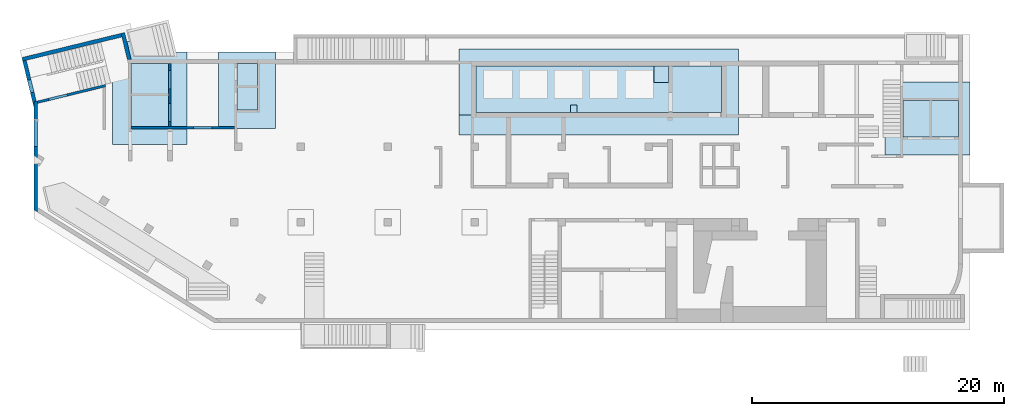
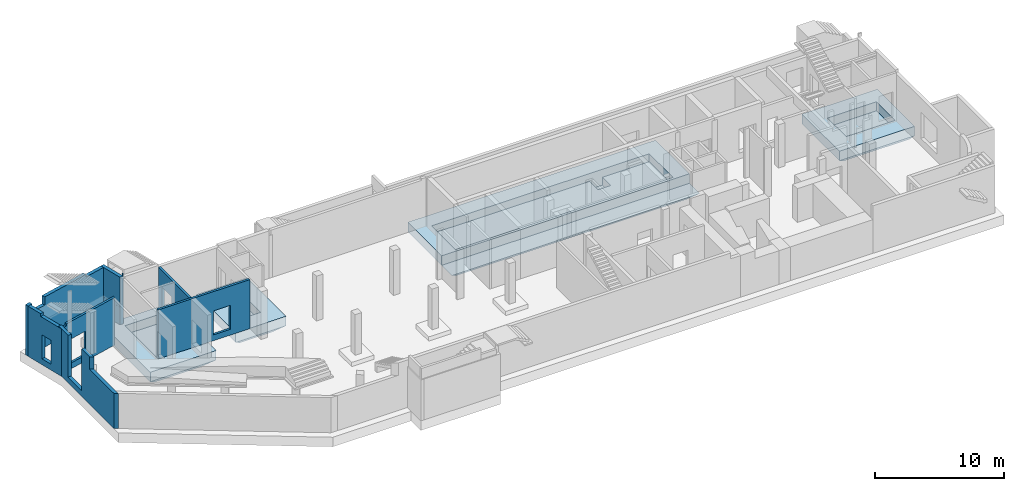
# One storey, part 5 of 9: 7 walls, 4 slabs, 7 openings.
"""IFC4 building model written with IfcOpenShell, lengths in millimetres."""

from ifc_helpers import new_model, entity, si_unit, converted_unit, derived_unit, direction, frame, origin, place, context, subcontext, project, spatial, indexed_curve, outline, extrude, polygons, material, type_object, element, save


model = new_model("IFC4")

# Units and contexts
model_context = context("Model", 3, precision=0.01, world=origin(), true_north=direction((6.12303176911189e-17, 1.0)))
plan_context = context("Plan", 3, precision=0.01, world=origin(), true_north=direction((6.12303176911189e-17, 1.0)))
body_context = subcontext(model_context, "Body", "Model", "MODEL_VIEW")
ifc_project = project(units=[si_unit("LENGTHUNIT", "METRE", prefix="MILLI"), si_unit("AREAUNIT", "SQUARE_METRE"), si_unit("VOLUMEUNIT", "CUBIC_METRE"), converted_unit("PLANEANGLEUNIT", "DEGREE", entity("IfcRatioMeasure", 0.0174532925199433), si_unit("PLANEANGLEUNIT", "RADIAN"), dimensions=[0, 0, 0, 0, 0, 0, 0]), si_unit("MASSUNIT", "GRAM", prefix="KILO"), derived_unit("MASSDENSITYUNIT", [(si_unit("MASSUNIT", "GRAM", prefix="KILO"), 1), (si_unit("LENGTHUNIT", "METRE"), -3)]), derived_unit("MOMENTOFINERTIAUNIT", [(si_unit("LENGTHUNIT", "METRE"), 4)]), si_unit("TIMEUNIT", "SECOND"), si_unit("FREQUENCYUNIT", "HERTZ"), si_unit("THERMODYNAMICTEMPERATUREUNIT", "DEGREE_CELSIUS"), derived_unit("THERMALTRANSMITTANCEUNIT", [(si_unit("MASSUNIT", "GRAM", prefix="KILO"), 1), (si_unit("THERMODYNAMICTEMPERATUREUNIT", "KELVIN"), -1), (si_unit("TIMEUNIT", "SECOND"), -3)]), derived_unit("VOLUMETRICFLOWRATEUNIT", [(si_unit("LENGTHUNIT", "METRE"), 3), (si_unit("TIMEUNIT", "SECOND"), -1)]), derived_unit("MASSFLOWRATEUNIT", [(si_unit("MASSUNIT", "GRAM", prefix="KILO"), 1), (si_unit("TIMEUNIT", "SECOND"), -1)]), derived_unit("ROTATIONALFREQUENCYUNIT", [(si_unit("TIMEUNIT", "SECOND"), -1)]), si_unit("ELECTRICCURRENTUNIT", "AMPERE"), si_unit("ELECTRICVOLTAGEUNIT", "VOLT"), si_unit("POWERUNIT", "WATT"), si_unit("FORCEUNIT", "NEWTON", prefix="KILO"), si_unit("ILLUMINANCEUNIT", "LUX"), si_unit("LUMINOUSFLUXUNIT", "LUMEN"), si_unit("LUMINOUSINTENSITYUNIT", "CANDELA"), derived_unit("USERDEFINED", [(si_unit("MASSUNIT", "GRAM", prefix="KILO"), -1), (si_unit("LENGTHUNIT", "METRE"), -2), (si_unit("TIMEUNIT", "SECOND"), 3), (si_unit("LUMINOUSFLUXUNIT", "LUMEN"), 1)]), derived_unit("LINEARVELOCITYUNIT", [(si_unit("LENGTHUNIT", "METRE"), 1), (si_unit("TIMEUNIT", "SECOND"), -1)]), si_unit("PRESSUREUNIT", "PASCAL"), derived_unit("USERDEFINED", [(si_unit("LENGTHUNIT", "METRE"), -2), (si_unit("MASSUNIT", "GRAM", prefix="KILO"), 1), (si_unit("TIMEUNIT", "SECOND"), -2)]), derived_unit("LINEARFORCEUNIT", [(si_unit("MASSUNIT", "GRAM", prefix="KILO"), 1), (si_unit("LENGTHUNIT", "METRE"), 1), (si_unit("TIMEUNIT", "SECOND"), -2), (si_unit("LENGTHUNIT", "METRE"), -1)]), derived_unit("PLANARFORCEUNIT", [(si_unit("MASSUNIT", "GRAM", prefix="KILO"), 1), (si_unit("LENGTHUNIT", "METRE"), 1), (si_unit("TIMEUNIT", "SECOND"), -2), (si_unit("LENGTHUNIT", "METRE"), -2)])], contexts=[model_context, plan_context])

# Site, building, storey
site_placement = place(None, origin())
site = spatial("IfcSite", under=ifc_project, at=site_placement, CompositionType="ELEMENT")
building_placement = place(site_placement, origin())
building = spatial("IfcBuilding", under=site, at=building_placement, CompositionType="ELEMENT")
storey_placement = place(building_placement, frame((0.0, 0.0, -4900.0)))
storey = spatial("IfcBuildingStorey", under=building, at=storey_placement, CompositionType="ELEMENT", Elevation=-4900.0)

# Slabs
ifc_material = material()
slab_type_1 = type_object("IfcSlabType", PredefinedType="BASESLAB", material=ifc_material)
slab_1_placement = place(storey_placement, frame((67520.0002685546, 13019.999226356, -1750.0)))
element("IfcSlab", 1, at=slab_1_placement, inside=storey, type_object=slab_type_1, PredefinedType="BASESLAB", context=body_context, shape_type="Tessellation", body=[
    polygons([(1450.00000000004, 4349.99999999999, 1750.0), (5850.00000000005, 4349.99999999999, 1750.0), (5850.00000000005, 1449.99999999998, 1750.0), (1450.00000000004, 1449.99999999998, 1750.0), (6750.00000000002, 5799.99999999999, 1750.0), (4.33146851719357e-11, 5799.99999999999, 1750.0), (4.33146851719357e-11, -2.16573425859679e-12, 1750.0), (6750.00000000002, -2.16573425859679e-12, 1750.0), (6750.00000000002, 4949.99999999999, 0.0), (6750.00000000002, 850.000000000025, 0.0), (850.000000000006, 850.000000000025, 0.0), (850.000000000023, 4949.99999999999, 0.0), (6750.00000000002, 5799.99999999999, 849.999999999998), (4.33146851719357e-11, 5799.99999999999, 849.999999999997), (3.46517481375486e-11, 1.51601398101775e-11, 849.999999999995), (6750.00000000002, -2.16573425859679e-12, 850.00000000002), (5850.00000000005, 4349.99999999999, 899.999999999999), (3750.00000000004, 4349.99999999999, 899.999999999999), (3550.00000000004, 4349.99999999999, 899.999999999999), (1450.00000000004, 4349.99999999999, 899.999999999999), (1450.00000000004, 1449.99999999998, 899.999999999999), (3550.00000000003, 1449.99999999998, 899.999999999999), (3750.00000000003, 1449.99999999998, 899.999999999999), (5850.00000000005, 1449.99999999998, 899.999999999999)], [[[5, 6, 7, 8], [1, 2, 3, 4]], [[9, 10, 11, 12]], [[6, 5, 13, 14]], [[7, 6, 14, 15]], [[8, 7, 15, 16]], [[5, 8, 16, 10, 9, 13]], [[11, 10, 16, 15]], [[9, 12, 14, 13]], [[12, 11, 15, 14]], [[17, 18, 19, 20, 21, 22, 23, 24]], [[2, 1, 20, 19, 18, 17]], [[1, 4, 21, 20]], [[4, 3, 24, 23, 22, 21]], [[3, 2, 17, 24]]], closed=True),
])
slab_type_2 = type_object("IfcSlabType", PredefinedType="BASESLAB", material=ifc_material)
slab_2_placement = place(storey_placement, frame((14650.0002685547, 15149.9992263559, -1750.0)))
element("IfcSlab", 2, at=slab_2_placement, inside=storey, type_object=slab_type_2, PredefinedType="BASESLAB", context=body_context, shape_type="Tessellation", body=[
    polygons([(-2.16573425859679e-12, 6050.00000000001, 1750.00000000001), (1.08286712929839e-11, 0.0, 1750.00000000001), (4525.0, 8.66293703438714e-12, 1750.00000000001), (4524.99999999999, 6050.00000000001, 1750.00000000001), (1450.00000000001, 1450.0, 1750.0), (1450.0, 5150.0, 1750.0), (3075.0, 5150.00000000001, 1750.0), (3075.0, 5100.00000000023, 1750.00000000001), (3075.00000000001, 1450.00000000001, 1750.0), (849.999999999993, 6050.00000000001, 4.33146851719357e-12), (3674.99999999997, 6050.00000000001, 3.24860138789518e-12), (3674.99999999998, 849.99999999998, 5.41433564649196e-12), (850.000000000002, 849.999999999995, 3.24860138789518e-12), (-2.16573425859679e-12, 6050.00000000001, 850.0), (1.08286712929839e-11, 0.0, 850.000000000001), (4524.99999999998, 6.49720277579036e-12, 850.000000000001), (4524.99999999999, 6050.00000000001, 850.00000000002), (1450.0, 5150.0, 900.000000000003), (1450.00000000001, 1450.0, 900.000000000003), (3075.00000000001, 1450.00000000001, 900.000000000003), (3075.0, 5150.00000000001, 900.000000000003)], [[[1, 2, 3, 4], [5, 6, 7, 8, 9]], [[10, 11, 12, 13]], [[2, 1, 14, 15]], [[3, 2, 15, 16]], [[4, 3, 16, 17]], [[1, 4, 17, 11, 10, 14]], [[12, 11, 17, 16]], [[10, 13, 15, 14]], [[13, 12, 16, 15]], [[18, 19, 20, 21]], [[6, 5, 19, 18]], [[5, 9, 20, 19]], [[9, 8, 7, 21, 20]], [[7, 6, 18, 21]]], closed=True),
])
slab_type_3 = type_object("IfcSlabType", PredefinedType="BASESLAB", material=ifc_material)
slab_3_placement = place(storey_placement, frame((6250.00026855467, 13849.9992263559, -1750.0)))
element("IfcSlab", 3, at=slab_3_placement, inside=storey, type_object=slab_type_3, PredefinedType="BASESLAB", context=body_context, shape_type="Tessellation", body=[
    polygons([(-1.08286712929839e-12, 8200.00000000004, 1750.00000000001), (1.40772726808791e-11, 3.68174823961454e-11, 1750.00000000001), (5900.00000000001, 4.54804194305325e-11, 1750.00000000001), (5900.0, 7350.00000000009, 1750.00000000001), (1950.50878437107, 7350.0000000001, 1750.0), (1743.31229154819, 8200.00000000004, 1750.00000000001), (1450.00000000001, 1450.00000000004, 1750.0), (1450.0, 6450.00000000009, 1750.0), (4450.0, 6450.0000000001, 1750.0), (4450.00000000001, 1450.00000000005, 1750.0), (5049.99999999999, 849.999999999991, 3.24860138789518e-12), (850.000000000003, 850.000000000015, 4.33146851719357e-12), (849.999999999993, 7350.00000000009, 3.24860138789518e-12), (1950.50878437107, 7350.0000000001, 4.33146851719357e-12), (5049.99999999998, 7350.00000000009, 5.41433564649196e-12), (3.24860138789518e-12, 8200.00000000005, 849.999999999984), (1.40772726808791e-11, 3.46517481375486e-11, 849.999999999995), (5900.00000000001, 3.46517481375486e-11, 849.999999999996), (5900.0, 7350.00000000009, 850.00000000002), (1743.31229154819, 8200.00000000004, 849.999999999957), (1450.0, 6450.00000000009, 900.000000000003), (1450.00000000001, 1450.00000000004, 900.000000000003), (4450.00000000001, 1450.00000000005, 900.000000000003), (4450.0, 6450.0000000001, 900.000000000003)], [[[1, 2, 3, 4, 5, 6], [7, 8, 9, 10]], [[11, 12, 13, 14, 15]], [[2, 1, 16, 17]], [[3, 2, 17, 18]], [[3, 18, 19, 4]], [[16, 1, 6, 20]], [[18, 11, 15, 19]], [[17, 16, 13, 12]], [[12, 11, 18, 17]], [[21, 22, 23, 24]], [[8, 7, 22, 21]], [[7, 10, 23, 22]], [[10, 9, 24, 23]], [[9, 8, 21, 24]], [[13, 16, 20, 14]], [[5, 4, 19, 15, 14]], [[6, 5, 14, 20]]], closed=True),
])
slab_type_4 = type_object("IfcSlabType", PredefinedType="BASESLAB", material=ifc_material)
slab_4_placement = place(storey_placement, frame((33720.0002685547, 14599.9992263559, -1800.0)))
element("IfcSlab", 4, at=slab_4_placement, inside=storey, type_object=slab_type_4, PredefinedType="BASESLAB", context=body_context, shape_type="Tessellation", body=[
    polygons([(22200.0, 6850.00000000012, 1800.0), (-4.33146851719357e-12, 6850.00000000008, 1800.0), (8.66293703438714e-12, 1600.00000000008, 1800.0), (22200.0, 1600.00000000012, 1800.0), (20850.0, 5500.00000000027, 1800.00000000001), (20850.0, 1800.00000000025, 1800.00000000001), (1350.00000000001, 1800.00000000021, 1800.00000000001), (1350.00000000001, 5500.00000000024, 1800.00000000001), (21450.0, 750.000000000005, 150.000000000005), (750.00000000002, 750.000000000109, 150.000000000004), (750.000000000016, 3850.00000000021, 150.000000000005), (750.000000000011, 6100.00000000015, 150.000000000005), (15150.0, 6100.00000000015, 150.000000000005), (15150.0, 5500.00000000026, 150.000000000005), (15150.0, 3850.00000000016, 150.000000000002), (17000.0, 3850.00000000016, 150.000000000008), (17000.0, 5500.00000000026, 150.000000000005), (17000.0, 6100.00000000015, 150.000000000006), (21450.0, 6100.00000000015, 150.000000000005), (21450.0, 3850.00000000015, 150.000000000005), (4.33146851719357e-12, 6850.00000000009, 899.999999999995), (1.29944055515807e-11, 1600.00000000008, 900.000000000014), (22200.0, 6850.00000000012, 899.99999999999), (22200.0, 1600.00000000012, 900.000000000003), (1350.00000000001, 5500.00000000024, 1050.00000000001), (15500.0, 5500.00000000023, 1050.00000000001), (15500.0, 5500.00000000017, 300.000000000005), (16650.0, 5500.0000000002, 300.000000000005), (16650.0, 5500.00000000027, 1050.00000000001), (16950.0, 5500.00000000027, 1050.00000000001), (20850.0, 5500.00000000027, 1050.00000000001), (15300.0, 5950.00000000015, 3.24860138789518e-12), (16850.0, 5950.00000000015, 5.41433564649196e-12), (16850.0, 4000.00000000016, 7.58006990508875e-12), (15300.0, 4000.00000000016, 7.58006990508875e-12), (22200.0, 5.84748249821132e-11, 899.999999999991), (1.29944055515807e-11, 9.52923073782586e-11, 900.000000000013), (1350.00000000001, 1800.00000000021, 1050.00000000001), (8860.00000000002, 1800.00000000022, 1050.00000000001), (8860.00000000002, 2400.00000000022, 1050.00000000001), (9360.00000000002, 2400.00000000022, 1050.00000000001), (9360.00000000002, 1800.00000000022, 1050.00000000001), (16650.0, 1800.00000000024, 1050.00000000001), (16950.0, 1800.00000000024, 1050.00000000001), (20850.0, 1800.00000000025, 1050.00000000001), (16650.0, 4200.00000000016, 1050.00000000001), (15500.0, 4200.00000000016, 1050.00000000001), (9360.00000000002, 1800.00000000022, 800.000000000005), (8860.00000000002, 1800.00000000022, 800.000000000005), (9360.00000000002, 2400.00000000022, 800.000000000005), (8860.00000000002, 2400.00000000022, 800.000000000005), (15500.0, 4200.00000000016, 300.000000000005), (16650.0, 4200.00000000016, 300.000000000005)], [[[1, 2, 3, 4], [5, 6, 7, 8]], [[9, 10, 11, 12, 13, 14, 15, 16, 17, 18, 19, 20]], [[2, 21, 22, 3]], [[23, 1, 4, 24]], [[2, 1, 23, 21]], [[8, 25, 26, 27, 28, 29, 30, 31, 5]], [[32, 33, 34, 35]], [[20, 19, 23, 24, 36, 9]], [[11, 10, 37, 22, 21, 12]], [[10, 9, 36, 37]], [[25, 38, 39, 40, 41, 42, 43, 44, 45, 31, 30, 29, 46, 47, 26]], [[8, 7, 38, 25]], [[7, 6, 45, 44, 43, 42, 48, 49, 39, 38]], [[6, 5, 31, 45]], [[33, 32, 13, 12, 21, 23, 19, 18]], [[49, 48, 50, 51]], [[42, 41, 50, 48]], [[41, 40, 51, 50]], [[40, 39, 49, 51]], [[35, 34, 16, 15]], [[34, 33, 18, 17, 16]], [[32, 35, 15, 14, 13]], [[28, 27, 52, 53]], [[26, 47, 52, 27]], [[47, 46, 53, 52]], [[46, 29, 28, 53]], [[24, 22, 37, 36]], [[22, 24, 4, 3]]], closed=True),
])

# Wall, openings
wall_type_1 = type_object("IfcWallType", PredefinedType="STANDARD")
wall_1_placement = place(storey_placement, frame((10800.0002685547, 20299.9992263564, 0.0), z_axis=(0.0, 0.0, 1.0), x_axis=(0.0, -1.0, 0.0)))
wall_1 = element("IfcWall", 5, at=wall_1_placement, inside=storey, type_object=wall_type_1, material=ifc_material, PredefinedType="NOTDEFINED", context=body_context, shape_type="Tessellation", body=[
    polygons([(579.999999999998, -100.000000000002, 2919.99999999804), (2020.0, -100.000000000002, 2919.99999999804), (2020.0, -100.000000000002, 550.0), (579.999999999998, -100.000000000002, 550.0), (3180.0, -100.000000000002, 2919.99999999804), (4620.0, -100.000000000002, 2919.99999999804), (4620.0, -100.000000000002, 550.0), (3180.0, -100.000000000002, 550.0), (0.0, -100.000000000002, 0.0), (2399.99999999999, -100.000000000001, 0.0), (2599.99999999999, -100.000000000001, 0.0), (5000.00000000048, -100.000000000002, 0.0), (5000.00000000048, -100.000000000002, 4500.0), (0.0, -100.000000000002, 4500.0), (5000.00000000048, 99.9999999999976, 0.0), (0.0, 99.9999999999985, 0.0), (0.0, 99.9999999999985, 4500.0), (5000.00000000048, 99.9999999999976, 4500.0), (2020.0, 99.9999999999977, 2919.99999999804), (579.999999999998, 99.9999999999976, 2919.99999999804), (579.999999999998, 99.9999999999976, 550.0), (2020.0, 99.9999999999977, 550.0), (4620.0, 99.9999999999982, 2919.99999999804), (3180.0, 99.9999999999981, 2919.99999999804), (3180.0, 99.9999999999981, 550.0), (4620.0, 99.9999999999982, 550.0)], [[[9, 10, 11, 12, 13, 14], [1, 2, 3, 4], [5, 6, 7, 8]], [[15, 16, 17, 18], [19, 20, 21, 22], [23, 24, 25, 26]], [[12, 11, 10, 9, 16, 15]], [[14, 13, 18, 17]], [[9, 14, 17, 16]], [[13, 12, 15, 18]], [[19, 2, 1, 20]], [[20, 1, 4, 21]], [[21, 4, 3, 22]], [[2, 19, 22, 3]], [[23, 6, 5, 24]], [[24, 5, 8, 25]], [[25, 8, 7, 26]], [[6, 23, 26, 7]]], closed=True),
])
opening_1_placement = place(wall_1_placement, frame((20299.9992263564, -10800.0002685547, 0.0), z_axis=(0.0, 0.0, 1.0), x_axis=(0.0, 1.0, 0.0)))
element("IfcOpeningElement", 6, at=opening_1_placement, cuts=wall_1, PredefinedType="OPENING", context=body_context, shape_type="SweptSolid", body=[
    extrude(outline(indexed_curve([(-1184.99999999902, -719.999999999999), (1184.99999999902, -719.999999999999), (1184.99999999902, 720.000000000001), (-1184.99999999902, 720.000000000001), (-1184.99999999902, -719.999999999999)], self_intersect=False)), frame((10600.0002685547, 18999.9992263564, 1735.0), z_axis=(1.0, 0.0, 0.0), x_axis=(0.0, 0.0, -1.0)), (0.0, 0.0, 1.0), 400.000000001943),
])
opening_2_placement = place(wall_1_placement, frame((20299.9992263564, -10800.0002685547, 0.0), z_axis=(0.0, 0.0, 1.0), x_axis=(0.0, 1.0, 0.0)))
element("IfcOpeningElement", 7, at=opening_2_placement, cuts=wall_1, PredefinedType="OPENING", context=body_context, shape_type="SweptSolid", body=[
    extrude(outline(indexed_curve([(-1184.99999999902, -719.999999999999), (1184.99999999902, -719.999999999999), (1184.99999999902, 720.000000000001), (-1184.99999999902, 720.000000000001), (-1184.99999999902, -719.999999999999)], self_intersect=False)), frame((10600.0002685547, 16399.9992263564, 1735.0), z_axis=(1.0, 0.0, 0.0), x_axis=(0.0, 0.0, -1.0)), (0.0, 0.0, 1.0), 400.000000001943),
])

# Wall, opening
wall_2_placement = place(storey_placement, frame((7700.00026855468, 15199.9992263559, 0.0)))
wall_2 = element("IfcWall", 8, at=wall_2_placement, inside=storey, type_object=wall_type_1, material=ifc_material, PredefinedType="NOTDEFINED", context=body_context, shape_type="Tessellation", body=[
    polygons([(1.8769719247939e-12, -100.000000000001, 0.0), (99.9999999999986, -100.000000000001, 0.0), (2900.0, -100.000000000001, 0.0), (3300.0, -99.9999999999989, 0.0), (8199.99999999999, -99.9999999999989, 0.0), (8199.99999999999, -99.9999999999989, 4650.0), (3300.0, -99.9999999999989, 4650.0), (2900.0, -100.000000000001, 4650.0), (99.9999999999986, -100.000000000001, 4650.0), (1.8769719247939e-12, -100.000000000001, 4650.0), (1.8769719247939e-12, -100.000000000001, 4500.0), (4950.0, -100.000000000003, 2829.99999999804), (6450.0, -100.000000000001, 2829.99999999805), (6450.0, -100.000000000001, 550.0), (4950.0, -100.000000000003, 550.0), (8199.99999999999, 99.9999999999989, 0.0), (3200.0, 100.000000000001, 0.0), (3000.0, 99.9999999999989, 0.0), (2.16575659869695e-13, 100.000000000001, 0.0), (2.16575659869695e-13, 100.000000000001, 4650.0), (8199.99999999999, 99.9999999999989, 4650.0), (6450.0, 99.9999999999989, 2829.99999999805), (4950.0, 99.9999999999989, 2829.99999999804), (4950.0, 99.9999999999989, 550.0), (6450.0, 99.9999999999989, 550.0)], [[[1, 2, 3, 4, 5, 6, 7, 8, 9, 10, 11], [12, 13, 14, 15]], [[16, 17, 18, 19, 20, 21], [22, 23, 24, 25]], [[5, 4, 3, 2, 1, 19, 18, 17, 16]], [[10, 9, 8, 7, 6, 21, 20]], [[1, 11, 10, 20, 19]], [[6, 5, 16, 21]], [[22, 13, 12, 23]], [[23, 12, 15, 24]], [[24, 15, 14, 25]], [[13, 22, 25, 14]]], closed=True),
])
opening_3_placement = place(wall_2_placement, frame((-7700.00026855468, -15199.9992263559, 0.0)))
element("IfcOpeningElement", 9, at=opening_3_placement, cuts=wall_2, PredefinedType="OPENING", context=body_context, shape_type="SweptSolid", body=[
    extrude(outline(indexed_curve([(-1139.99999999902, -749.999999999998), (1139.99999999902, -749.999999999998), (1139.99999999902, 750.000000000001), (-1139.99999999902, 750.000000000001), (-1139.99999999902, -749.999999999998)], self_intersect=False)), frame((13400.0002685547, 14999.9992263559, 1690.0), z_axis=(0.0, 1.0, 0.0), x_axis=(0.0, 0.0, -1.0)), (0.0, 0.0, 1.0), 400.000000001943),
])

# Wall
wall_3_placement = place(storey_placement, frame((276.317659255633, 17216.0487599068, 0.0), z_axis=(0.0, 0.0, 1.0), x_axis=(0.971552058141472, 0.236826092990341, 0.0)))
element("IfcWall", 10, at=wall_3_placement, inside=storey, type_object=wall_type_1, material=ifc_material, PredefinedType="NOTDEFINED", context=body_context, shape_type="Tessellation", body=[
    polygons([(-5.41433564649196e-13, -100.000000000001, 0.0), (5352.26080416868, -100.000000000001, 0.0), (5558.1169889444, -100.000000000003, 0.0), (5558.1169889444, -100.000000000001, 4500.0), (5352.26080416868, -100.000000000001, 4500.0), (400.27581160053, -99.9999999999968, 4500.0), (400.27581160053, -100.000000000319, 4300.00000000001), (0.275811600527082, -100.000000000319, 4300.00000000001), (0.275811600527082, -100.000000000001, 4500.0), (0.0, -100.000000000001, 4500.0), (942.275811600532, -100.000000000003, 2829.99999999804), (2442.27581160053, -100.000000000003, 2829.99999999805), (2442.27581160053, -100.000000000003, 550.0), (942.275811600532, -100.000000000003, 550.0), (5606.86910490273, 99.9999999999968, 0.0), (48.7521159583319, 99.9999999999989, 0.0), (48.7521159583308, 99.9999999999989, 4300.00000000001), (400.275811600528, 99.9999999999989, 4300.00000000001), (400.275811600528, 99.9999999999989, 4500.0), (5606.86910490273, 99.9999999999989, 4500.0), (2442.27581160054, 100.000000000001, 2829.99999999805), (942.275811600533, 99.9999999999968, 2829.99999999804), (942.275811600534, 100.000000000001, 550.0), (2442.27581160054, 100.000000000001, 550.0), (0.275811600528165, -98.8685143399134, 4500.0), (0.275811600528165, -98.8685143399134, 4300.00000000001)], [[[1, 2, 3, 4, 5, 6, 7, 8, 9, 10], [11, 12, 13, 14]], [[15, 16, 17, 18, 19, 20], [21, 22, 23, 24]], [[3, 2, 1, 16, 15]], [[4, 3, 15, 20]], [[16, 1, 10, 25, 26, 17]], [[10, 9, 25]], [[21, 12, 11, 22]], [[22, 11, 14, 23]], [[23, 14, 13, 24]], [[12, 21, 24, 13]], [[18, 7, 6, 19]], [[7, 18, 17, 26, 8]], [[8, 26, 25, 9]], [[4, 20, 19, 6, 5]]], closed=True),
])

# Wall, opening
wall_type_2 = type_object("IfcWallType", PredefinedType="STANDARD")
wall_4_placement = place(storey_placement, frame((7058.33717491699, 22718.7484245087, 0.0), z_axis=(0.0, 0.0, 1.0), x_axis=(0.236826092990336, -0.971552058141474, 0.0)))
wall_4 = element("IfcWall", 11, at=wall_4_placement, inside=storey, type_object=wall_type_2, material=ifc_material, PredefinedType="NOTDEFINED", context=body_context, shape_type="Tessellation", body=[
    polygons([(4.33146851719357e-12, -149.999999999999, 0.0), (300.000000000005, -149.999999999999, 0.0), (2144.22404517247, -149.999999999999, 0.0), (2144.22404517247, -149.999999999999, 1670.0), (300.000000000005, -149.999999999998, 1670.0), (300.000000000005, -149.999999999998, 1870.0), (2144.22404517247, -149.999999999999, 1870.0), (2144.22404517246, -149.999999999999, 4500.0), (300.000000000005, -149.999999999999, 4500.0), (4.33146851719357e-12, -149.999999999999, 4500.0), (2217.35221910996, 150.000000000001, 0.0), (4.33146851719357e-12, 150.000000000003, 0.0), (4.33146851719357e-12, 150.000000000002, 4500.0), (2094.06944418373, 150.000000000003, 4500.0), (2094.06944418374, 150.000000000003, 4750.0), (2217.35221910996, 150.000000000001, 4750.0), (2210.43770763277, 121.634004632318, 4750.0), (2210.43770763277, 121.634004632318, 4650.0), (2210.43770763277, 121.634004632318, 4500.0), (2145.75382931356, -143.724234893089, 1870.0), (2145.75382931356, -143.724234893089, 1670.0), (300.000000000005, -143.724234893084, 1670.0), (300.000000000005, -143.724234893084, 1870.0)], [[[1, 2, 3, 4, 5, 6, 7, 8, 9, 10]], [[11, 12, 13, 14, 15, 16]], [[3, 2, 1, 12, 11]], [[16, 15, 17]], [[3, 11, 16, 17, 18, 19, 8, 7, 20, 21, 4]], [[12, 1, 10, 13]], [[19, 14, 13, 10, 9, 8]], [[14, 19, 18, 17, 15]], [[21, 22, 5, 4]], [[6, 23, 20, 7]], [[22, 23, 6, 5]], [[23, 22, 21, 20]]], closed=True),
])
opening_4_placement = place(storey_placement, frame((7058.33717491699, 22718.7484245087, 0.0), z_axis=(0.0, 0.0, 1.0), x_axis=(0.236826092990336, -0.971552058141474, 0.0)))
element("IfcOpeningElement", 12, at=opening_4_placement, cuts=wall_4, PredefinedType="OPENING", context=body_context, shape_type="SweptSolid", body=[
    extrude(outline(indexed_curve([(-923.25936069205, -3.13788255345677), (922.494468621501, -3.13788255345677), (922.494468621501, 3.13788255345893), (-921.729576550957, 3.13788255345464), (-923.25936069205, -3.13788255345677)], self_intersect=False)), frame((1222.49446862151, -146.862117446542, 1670.0), z_axis=(0.0, 0.0, 1.0), x_axis=(-1.0, 0.0, 0.0)), (0.0, 0.0, 1.0), 200.0),
])

wall_5_placement = place(storey_placement, frame((6948.12828014432, 22537.4917018389, 0.0), z_axis=(0.0, 0.0, 1.0), x_axis=(-0.971552058141474, -0.236826092990335, 0.0)))
wall_5 = element("IfcWall", 13, at=wall_5_placement, inside=storey, type_object=wall_type_2, material=ifc_material, PredefinedType="NOTDEFINED", context=body_context, shape_type="Tessellation", body=[
    polygons([(1.08286712929839e-12, -150.000000000001, 0.0), (8099.99206966279, -150.000000000001, 0.0), (8099.99206966279, -150.000000000001, 4750.0), (7649.99206966279, -150.000000000005, 4750.0), (7649.99206966279, -150.000000000005, 3970.00000000001), (6299.99206966279, -150.000000000005, 3970.00000000001), (6299.99206966279, -149.999999999996, 4750.0), (1900.00000000001, -150.000000000005, 4750.0), (1900.00000000001, -150.000000000001, 4500.0), (1.08286712929839e-12, -150.000000000001, 4500.0), (8099.99206966279, 150.000000000001, 0.0), (7799.99206966279, 150.000000000001, 0.0), (-1.08286712929839e-12, 150.000000000001, 0.0), (0.0, 150.000000000001, 1670.0), (0.0, 150.000000000001, 1870.0), (-1.08286712929839e-12, 150.000000000001, 4500.0), (1900.00000000002, 150.000000000001, 4500.0), (1900.00000000002, 149.999999999996, 4750.0), (1930.93783039304, 150.000000000001, 4750.0), (6299.99206966279, 150.000000000001, 4750.0), (6299.99206966279, 150.000000000321, 3970.00000000001), (7649.99206966279, 150.000000000321, 3970.00000000001), (7649.99206966279, 150.000000000001, 4750.0), (7799.99206966279, 150.000000000001, 4750.0), (8099.99206966279, 150.000000000001, 4750.0), (7649.99206966278, -49.999999999993, 4750.0), (6299.99206966278, -49.9999999999973, 4750.0)], [[[1, 2, 3, 4, 5, 6, 7, 8, 9, 10]], [[11, 12, 13, 14, 15, 16, 17, 18, 19, 20, 21, 22, 23, 24, 25]], [[2, 1, 13, 12, 11]], [[3, 25, 24, 23, 26, 4]], [[13, 1, 10, 16, 15, 14]], [[3, 2, 11, 25]], [[6, 21, 20, 27, 7]], [[21, 6, 5, 22]], [[22, 5, 4, 26, 23]], [[9, 17, 16, 10]], [[17, 9, 8, 18]], [[7, 27, 20, 19, 18, 8]]], closed=True),
])
opening_5_placement = place(wall_5_placement, frame((12087.9344363538, 20250.8483740858, 0.0), z_axis=(0.0, 0.0, 1.0), x_axis=(-0.971552058141474, 0.236826092990335, 0.0)))
element("IfcOpeningElement", 14, at=opening_5_placement, cuts=wall_5, PredefinedType="OPENING", context=body_context, shape_type="SweptSolid", body=[
    extrude(outline(indexed_curve([(-1089.99999999999, -675.0), (1089.99999999999, -675.0), (1089.99999999999, 675.0), (-1089.99999999999, 675.0), (-1089.99999999999, -675.0)], self_intersect=False)), frame((136.036465394436, 21031.3643900633, 5060.0), z_axis=(0.236826092990334, -0.971552058141474, 0.0), x_axis=(0.0, 0.0, -1.0)), (0.0, 0.0, 1.0), 300.000000000971),
])

# Wall, openings
wall_6_placement = place(storey_placement, frame((-740.178963396406, 20508.9933319553, 0.0), z_axis=(0.0, 0.0, 1.0), x_axis=(0.236826092990336, -0.971552058141473, 0.0)))
wall_6 = element("IfcWall", 15, at=wall_6_placement, inside=storey, type_object=wall_type_2, material=ifc_material, PredefinedType="NOTDEFINED", context=body_context, shape_type="Tessellation", body=[
    polygons([(8.66293703438714e-12, -150.000000000001, 0.0), (3740.77040872538, -149.999999999999, 0.0), (3740.77040872538, -150.0, 4500.0), (1420.00000000001, -150.000000000001, 4500.0), (1420.00000000001, -150.0, 4750.0), (4.33146851719357e-12, -150.000000000001, 4750.0), (1570.00000000005, -150.000000000001, 2829.99999999804), (2590.00000000005, -149.999999999999, 2829.99999999805), (2590.00000000005, -149.999999999999, 550.0), (1570.00000000005, -150.0, 550.0), (3340.00000000005, 150.000000000001, 0.0), (8.66293703438714e-12, 150.0, 0.0), (8.66293703438714e-12, 150.0, 4750.0), (1420.00000000001, 150.000000000001, 4750.0), (1420.00000000001, 150.000000000001, 4500.0), (3340.00000000005, 150.000000000001, 4500.0), (2590.00000000006, 150.0, 2829.99999999805), (1570.00000000005, 150.000000000001, 2829.99999999804), (1570.00000000005, 150.000000000001, 550.0), (2590.00000000005, 150.000000000001, 550.0), (3340.00000000005, -52.3079728057761, 0.0), (3340.00000000006, -52.3079728057772, 4500.0)], [[[1, 2, 3, 4, 5, 6], [7, 8, 9, 10]], [[11, 12, 13, 14, 15, 16], [17, 18, 19, 20]], [[2, 1, 12, 11, 21]], [[13, 6, 5, 14]], [[1, 6, 13, 12]], [[21, 11, 16, 22]], [[2, 21, 22, 3]], [[15, 4, 3, 22, 16]], [[4, 15, 14, 5]], [[17, 8, 7, 18]], [[18, 7, 10, 19]], [[19, 10, 9, 20]], [[8, 17, 20, 9]]], closed=True),
])
opening_6_placement = place(wall_6_placement, origin())
element("IfcOpeningElement", 16, at=opening_6_placement, cuts=wall_6, PredefinedType="OPENING", context=body_context, shape_type="SweptSolid", body=[
    extrude(outline(indexed_curve([(-150.000000000483, -1089.99999999999), (150.000000000484, -1089.99999999999), (150.000000000478, 1089.99999999999), (-150.000000000484, 1089.99999999999), (-150.000000000483, -1089.99999999999)], self_intersect=False)), frame((-150.0, 300.0, 5060.0), z_axis=(0.0, 1.0, 0.0), x_axis=(-1.0, 0.0, 0.0)), (0.0, 0.0, 1.0), 1350.0),
])
opening_7_placement = place(wall_6_placement, frame((20100.8483740858, -4137.94236669103, 0.0), z_axis=(0.0, 0.0, 1.0), x_axis=(0.236826092990336, 0.971552058141473, 0.0)))
element("IfcOpeningElement", 17, at=opening_7_placement, cuts=wall_6, PredefinedType="OPENING", context=body_context, shape_type="SweptSolid", body=[
    extrude(outline(indexed_curve([(-1139.99999999902, -509.999999999999), (1139.99999999902, -509.999999999999), (1139.99999999902, 510.000000000002), (-1139.99999999902, 510.000000000002), (-1139.99999999902, -509.999999999999)], self_intersect=False)), frame((-490.468704511864, 18428.9585277734, 1690.0), z_axis=(0.971552058141474, 0.236826092990336, 0.0), x_axis=(0.0, 0.0, -1.0)), (0.0, 0.0, 1.0), 500.000000001943),
])

# Wall
wall_7_placement = place(storey_placement, frame((150.000268554654, 8501.69671829517, 0.0), z_axis=(0.0, 0.0, 1.0), x_axis=(0.0, 1.0, 0.0)))
element("IfcWall", 18, at=wall_7_placement, inside=storey, type_object=wall_type_2, material=ifc_material, PredefinedType="NOTDEFINED", context=body_context, shape_type="Tessellation", body=[
    polygons([(1.08286712929839e-12, -150.0, 0.0), (353.751582317484, -150.0, 0.0), (8617.19683579752, -150.0, 0.0), (8823.05302057324, -150.0, 0.0), (8823.05302057324, -150.0, 4300.00000000001), (8618.36145240309, -150.0, 4300.00000000001), (8618.36145240309, -150.0, 4500.0), (8617.19683579751, -150.0, 4500.0), (7298.30250806127, -150.0, 4500.0), (7298.30250806127, -150.0, 550.0), (5198.30250806128, -150.0, 550.0), (5198.30250806128, -150.0, 4500.0), (4598.77057012725, -150.0, 4500.0), (3773.35021138651, -150.0, 4500.0), (3773.35021138651, -150.0, 3330.0), (353.751582317485, -150.0, 3330.0), (1.19115384222823e-11, -150.0, 3330.0), (8749.92484663574, 150.0, 0.0), (8337.41951007973, 150.0, 0.0), (187.457147082003, 150.0, 0.0), (187.457147082003, 150.0, 3330.0), (3960.80735846851, 150.000000000003, 3330.0), (3960.80735846851, 150.000000000004, 3580.0), (3960.80735846851, 150.000000000003, 4500.0), (5198.30250806128, 150.000000000001, 4500.0), (5198.30250806128, 150.0, 550.0), (7298.30250806127, 150.0, 550.0), (7298.30250806127, 150.0, 4500.0), (8337.41951007972, 150.0, 4500.0), (8749.92484663574, 150.0, 4500.0), (8797.83665341613, -46.5527273578813, 0.0), (8797.83665341613, -46.5527273578805, 4500.0), (8811.57256680957, -102.902746730084, 4500.0), (8811.57256680957, -102.902746730084, 4300.00000000001)], [[[1, 2, 3, 4, 5, 6, 7, 8, 9, 10, 11, 12, 13, 14, 15, 16, 17]], [[18, 19, 20, 21, 22, 23, 24, 25, 26, 27, 28, 29, 30]], [[4, 3, 2, 1, 20, 19, 18, 31]], [[1, 17, 21, 20]], [[24, 14, 13, 12, 25]], [[14, 24, 23, 22, 15]], [[17, 16, 15, 22, 21]], [[4, 31, 18, 30, 32, 33, 34, 5]], [[34, 6, 5]], [[6, 34, 33, 7]], [[27, 10, 9, 28]], [[10, 27, 26, 11]], [[11, 26, 25, 12]], [[30, 29, 28, 9, 8, 7, 33, 32]]], closed=True),
])

save(model, "model.ifc")
